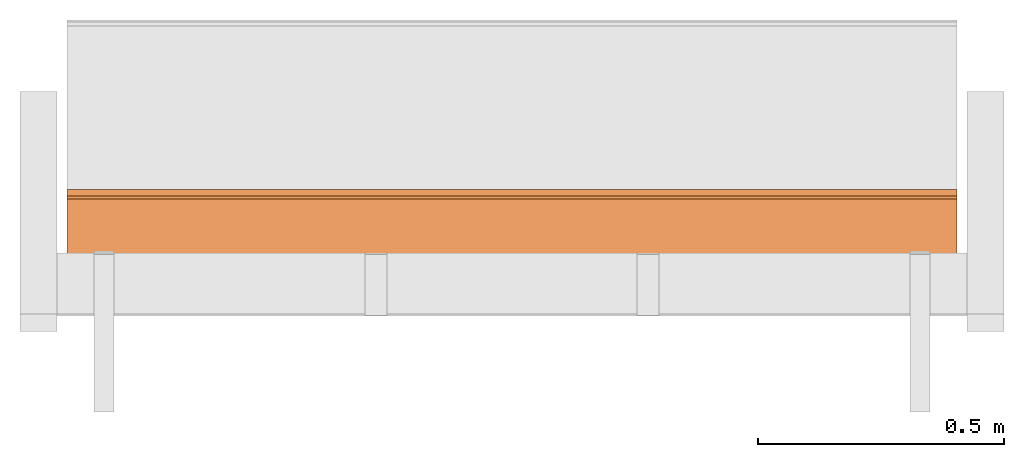
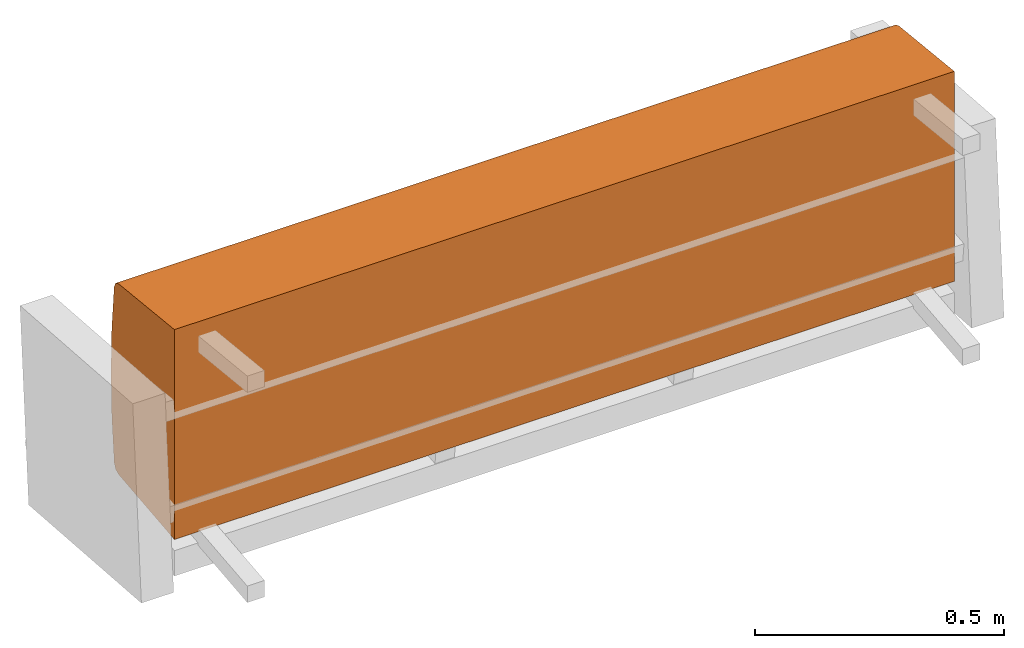
# One storey, part 1 of 4: 1 proxy, 1 element without a shape of its own.
"""IFC2X3 building model written with IfcOpenShell, lengths in metres."""

from ifc_helpers import new_model, si_unit, direction, origin_with_axes, place, context, project, spatial, faceted_brep, source, transform, mapped, element, aggregate, save


model = new_model("IFC2X3")

# Units and contexts
model_context = context("Model", 3, precision=1e-06, world=origin_with_axes(), true_north=direction((0.0, 1.0, 0.0)))
ifc_project = project(units=[si_unit("LENGTHUNIT", "METRE"), si_unit("AREAUNIT", "SQUARE_METRE"), si_unit("VOLUMEUNIT", "CUBIC_METRE")], contexts=[model_context])

# Site, building, storey
site_placement = place(None, origin_with_axes())
site = spatial("IfcSite", under=ifc_project, at=site_placement, CompositionType="ELEMENT")
building_placement = place(site_placement, origin_with_axes())
building = spatial("IfcBuilding", under=site, at=building_placement, Name="Default Building", CompositionType="ELEMENT")
storey_placement = place(building_placement, origin_with_axes())
storey = spatial("IfcBuildingStorey", under=building, at=storey_placement, Name="Default Storey", CompositionType="ELEMENT", Elevation=0.0)

# Assembly, proxy
assembly_placement = place(storey_placement, origin_with_axes())
assembly = element("IfcElementAssembly", 1, at=assembly_placement, inside=storey, Name="H-04-084-A_3-seater", ObjectType="H-04-084-A_3-seater", AssemblyPlace="NOTDEFINED", PredefinedType="NOTDEFINED")
shared_shape = source(origin_with_axes(), model_context, "Body", "Brep", [
    faceted_brep([(0.9049999713897705, -0.11101193726062775, -0.2574460208415985), (0.9049999713897705, -0.11100000143051147, 0.25755399465560913), (-0.9049999713897705, -0.11101193726062775, -0.2574460208415985), (-0.9049999713897705, -0.11101193726062775, -0.2574460208415985), (0.9049999713897705, -0.11100000143051147, 0.25755399465560913), (-0.9049999713897705, -0.11100000143051147, 0.25755399465560913), (0.9049999713897705, 0.11315424740314484, -0.23389045894145966), (0.9049999713897705, -0.11101193726062775, -0.2574460208415985), (-0.9049999713897705, 0.11315424740314484, -0.23389045894145966), (-0.9049999713897705, 0.11315424740314484, -0.23389045894145966), (0.9049999713897705, -0.11101193726062775, -0.2574460208415985), (-0.9049999713897705, -0.11101193726062775, -0.2574460208415985), (0.9049999713897705, 0.12509645521640778, -0.22825108468532562), (0.9049999713897705, 0.11315424740314484, -0.23389045894145966), (-0.9049999713897705, 0.12509645521640778, -0.22825108468532562), (-0.9049999713897705, 0.12509645521640778, -0.22825108468532562), (0.9049999713897705, 0.11315424740314484, -0.23389045894145966), (-0.9049999713897705, 0.11315424740314484, -0.23389045894145966), (0.9049999713897705, 0.1309199035167694, -0.21639753878116608), (0.9049999713897705, 0.12509645521640778, -0.22825108468532562), (-0.9049999713897705, 0.1309199035167694, -0.21639753878116608), (-0.9049999713897705, 0.1309199035167694, -0.21639753878116608), (0.9049999713897705, 0.12509645521640778, -0.22825108468532562), (-0.9049999713897705, 0.12509645521640778, -0.22825108468532562), (0.9049999713897705, 0.1406860649585724, -0.10837232321500778), (0.9049999713897705, 0.1309199035167694, -0.21639753878116608), (-0.9049999713897705, 0.1406860649585724, -0.10837232321500778), (-0.9049999713897705, 0.1406860649585724, -0.10837232321500778), (0.9049999713897705, 0.1309199035167694, -0.21639753878116608), (-0.9049999713897705, 0.1309199035167694, -0.21639753878116608), (0.9049999713897705, 0.1439555585384369, 4.417426316649653e-05), (0.9049999713897705, 0.1406860649585724, -0.10837232321500778), (-0.9049999713897705, 0.1439555585384369, 4.417426316649653e-05), (-0.9049999713897705, 0.1439555585384369, 4.417426316649653e-05), (0.9049999713897705, 0.1406860649585724, -0.10837232321500778), (-0.9049999713897705, 0.1406860649585724, -0.10837232321500778), (0.9049999713897705, 0.14071664214134216, 0.10846158862113953), (0.9049999713897705, 0.1439555585384369, 4.417426316649653e-05), (-0.9049999713897705, 0.14071664214134216, 0.10846158862113953), (-0.9049999713897705, 0.14071664214134216, 0.10846158862113953), (0.9049999713897705, 0.1439555585384369, 4.417426316649653e-05), (-0.9049999713897705, 0.1439555585384369, 4.417426316649653e-05), (0.9049999713897705, 0.1309809684753418, 0.21648956835269928), (0.9049999713897705, 0.14071664214134216, 0.10846158862113953), (-0.9049999713897705, 0.1309809684753418, 0.21648956835269928), (-0.9049999713897705, 0.1309809684753418, 0.21648956835269928), (0.9049999713897705, 0.14071664214134216, 0.10846158862113953), (-0.9049999713897705, 0.14071664214134216, 0.10846158862113953), (0.9049999713897705, 0.12515902519226074, 0.2283465564250946), (0.9049999713897705, 0.1309809684753418, 0.21648956835269928), (-0.9049999713897705, 0.12515902519226074, 0.2283465564250946), (-0.9049999713897705, 0.12515902519226074, 0.2283465564250946), (0.9049999713897705, 0.1309809684753418, 0.21648956835269928), (-0.9049999713897705, 0.1309809684753418, 0.21648956835269928), (0.9049999713897705, 0.11321509629487991, 0.23398803174495697), (0.9049999713897705, 0.12515902519226074, 0.2283465564250946), (-0.9049999713897705, 0.11321509629487991, 0.23398803174495697), (-0.9049999713897705, 0.11321509629487991, 0.23398803174495697), (0.9049999713897705, 0.12515902519226074, 0.2283465564250946), (-0.9049999713897705, 0.12515902519226074, 0.2283465564250946), (0.9049999713897705, -0.11100000143051147, 0.25755399465560913), (0.9049999713897705, 0.11321509629487991, 0.23398803174495697), (-0.9049999713897705, -0.11100000143051147, 0.25755399465560913), (-0.9049999713897705, -0.11100000143051147, 0.25755399465560913), (0.9049999713897705, 0.11321509629487991, 0.23398803174495697), (-0.9049999713897705, 0.11321509629487991, 0.23398803174495697), (0.9049999713897705, 0.1309809684753418, 0.21648956835269928), (0.9049999713897705, 0.12515902519226074, 0.2283465564250946), (0.9049999713897705, 0.14071664214134216, 0.10846158862113953), (0.9049999713897705, 0.14071664214134216, 0.10846158862113953), (0.9049999713897705, 0.12515902519226074, 0.2283465564250946), (0.9049999713897705, 0.11321509629487991, 0.23398803174495697), (0.9049999713897705, 0.14071664214134216, 0.10846158862113953), (0.9049999713897705, 0.11321509629487991, 0.23398803174495697), (0.9049999713897705, -0.11100000143051147, 0.25755399465560913), (0.9049999713897705, 0.12509645521640778, -0.22825108468532562), (0.9049999713897705, 0.1309199035167694, -0.21639753878116608), (0.9049999713897705, 0.11315424740314484, -0.23389045894145966), (0.9049999713897705, 0.11315424740314484, -0.23389045894145966), (0.9049999713897705, 0.1309199035167694, -0.21639753878116608), (0.9049999713897705, 0.1406860649585724, -0.10837232321500778), (0.9049999713897705, 0.11315424740314484, -0.23389045894145966), (0.9049999713897705, 0.1406860649585724, -0.10837232321500778), (0.9049999713897705, -0.11101193726062775, -0.2574460208415985), (0.9049999713897705, -0.11101193726062775, -0.2574460208415985), (0.9049999713897705, 0.1406860649585724, -0.10837232321500778), (0.9049999713897705, -0.11100000143051147, 0.25755399465560913), (0.9049999713897705, -0.11100000143051147, 0.25755399465560913), (0.9049999713897705, 0.1406860649585724, -0.10837232321500778), (0.9049999713897705, 0.1439555585384369, 4.417426316649653e-05), (0.9049999713897705, -0.11100000143051147, 0.25755399465560913), (0.9049999713897705, 0.1439555585384369, 4.417426316649653e-05), (0.9049999713897705, 0.14071664214134216, 0.10846158862113953), (-0.9049999713897705, 0.1406860649585724, -0.10837232321500778), (-0.9049999713897705, 0.1309199035167694, -0.21639753878116608), (-0.9049999713897705, 0.12509645521640778, -0.22825108468532562), (-0.9049999713897705, 0.12515902519226074, 0.2283465564250946), (-0.9049999713897705, 0.1309809684753418, 0.21648956835269928), (-0.9049999713897705, 0.11321509629487991, 0.23398803174495697), (-0.9049999713897705, 0.11321509629487991, 0.23398803174495697), (-0.9049999713897705, 0.1309809684753418, 0.21648956835269928), (-0.9049999713897705, 0.14071664214134216, 0.10846158862113953), (-0.9049999713897705, 0.11321509629487991, 0.23398803174495697), (-0.9049999713897705, 0.14071664214134216, 0.10846158862113953), (-0.9049999713897705, -0.11100000143051147, 0.25755399465560913), (-0.9049999713897705, -0.11100000143051147, 0.25755399465560913), (-0.9049999713897705, 0.14071664214134216, 0.10846158862113953), (-0.9049999713897705, 0.1439555585384369, 4.417426316649653e-05), (-0.9049999713897705, -0.11100000143051147, 0.25755399465560913), (-0.9049999713897705, 0.1439555585384369, 4.417426316649653e-05), (-0.9049999713897705, -0.11101193726062775, -0.2574460208415985), (-0.9049999713897705, -0.11101193726062775, -0.2574460208415985), (-0.9049999713897705, 0.1439555585384369, 4.417426316649653e-05), (-0.9049999713897705, 0.1406860649585724, -0.10837232321500778), (-0.9049999713897705, -0.11101193726062775, -0.2574460208415985), (-0.9049999713897705, 0.1406860649585724, -0.10837232321500778), (-0.9049999713897705, 0.11315424740314484, -0.23389045894145966), (-0.9049999713897705, 0.11315424740314484, -0.23389045894145966), (-0.9049999713897705, 0.1406860649585724, -0.10837232321500778), (-0.9049999713897705, 0.12509645521640778, -0.22825108468532562)], [[[0, 1, 2]], [[3, 4, 5]], [[6, 7, 8]], [[9, 10, 11]], [[12, 13, 14]], [[15, 16, 17]], [[18, 19, 20]], [[21, 22, 23]], [[24, 25, 26]], [[27, 28, 29]], [[30, 31, 32]], [[33, 34, 35]], [[36, 37, 38]], [[39, 40, 41]], [[42, 43, 44]], [[45, 46, 47]], [[48, 49, 50]], [[51, 52, 53]], [[54, 55, 56]], [[57, 58, 59]], [[60, 61, 62]], [[63, 64, 65]], [[66, 67, 68]], [[69, 70, 71]], [[72, 73, 74]], [[75, 76, 77]], [[78, 79, 80]], [[81, 82, 83]], [[84, 85, 86]], [[87, 88, 89]], [[90, 91, 92]], [[93, 94, 95]], [[96, 97, 98]], [[99, 100, 101]], [[102, 103, 104]], [[105, 106, 107]], [[108, 109, 110]], [[111, 112, 113]], [[114, 115, 116]], [[117, 118, 119]]]),
])
proxy_placement = place(assembly_placement, origin_with_axes())
proxy = element("IfcBuildingElementProxy", 2, at=proxy_placement, Name="1", ObjectType="1", CompositionType="ELEMENT", context=model_context, shape_type="MappedRepresentation", body=[
    mapped(shared_shape, transform((0.0, 0.0, 0.0), scale=1.0)),
])
aggregate(assembly, [proxy])

save(model, "model.ifc")
